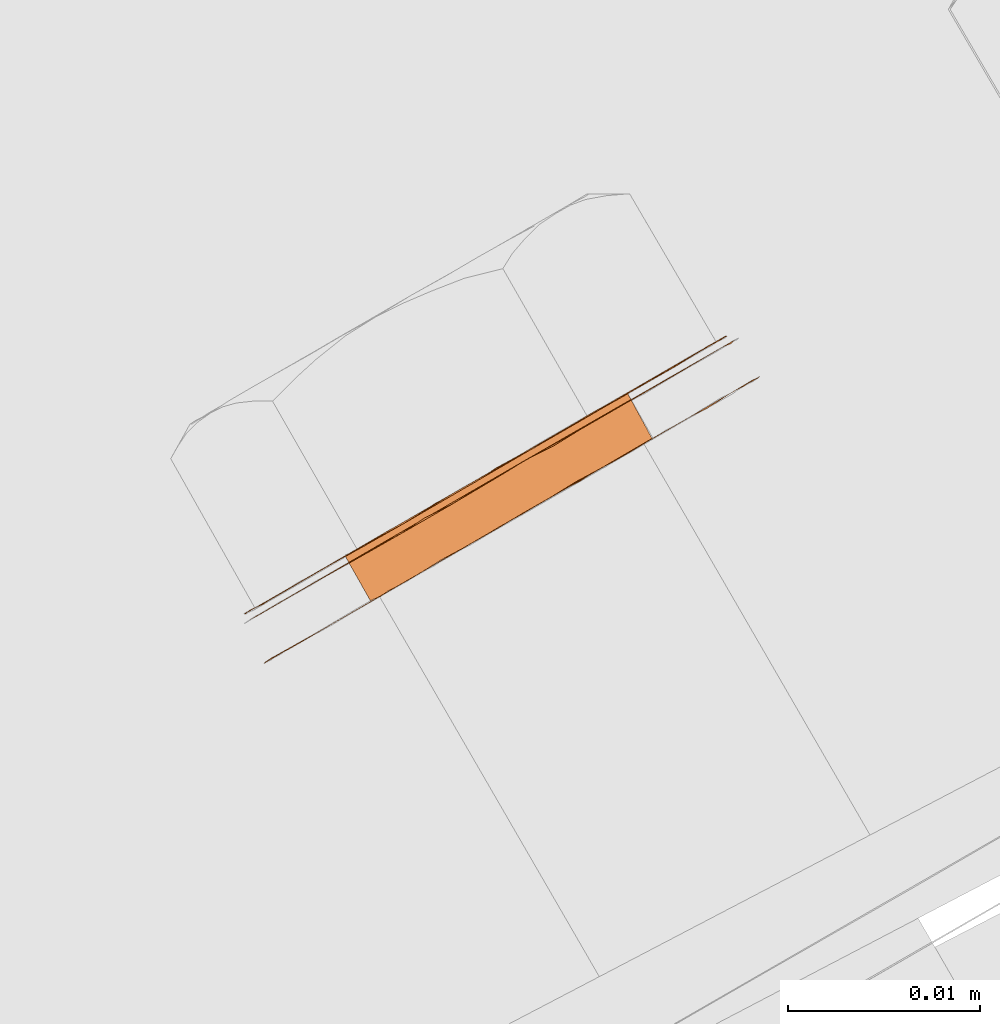
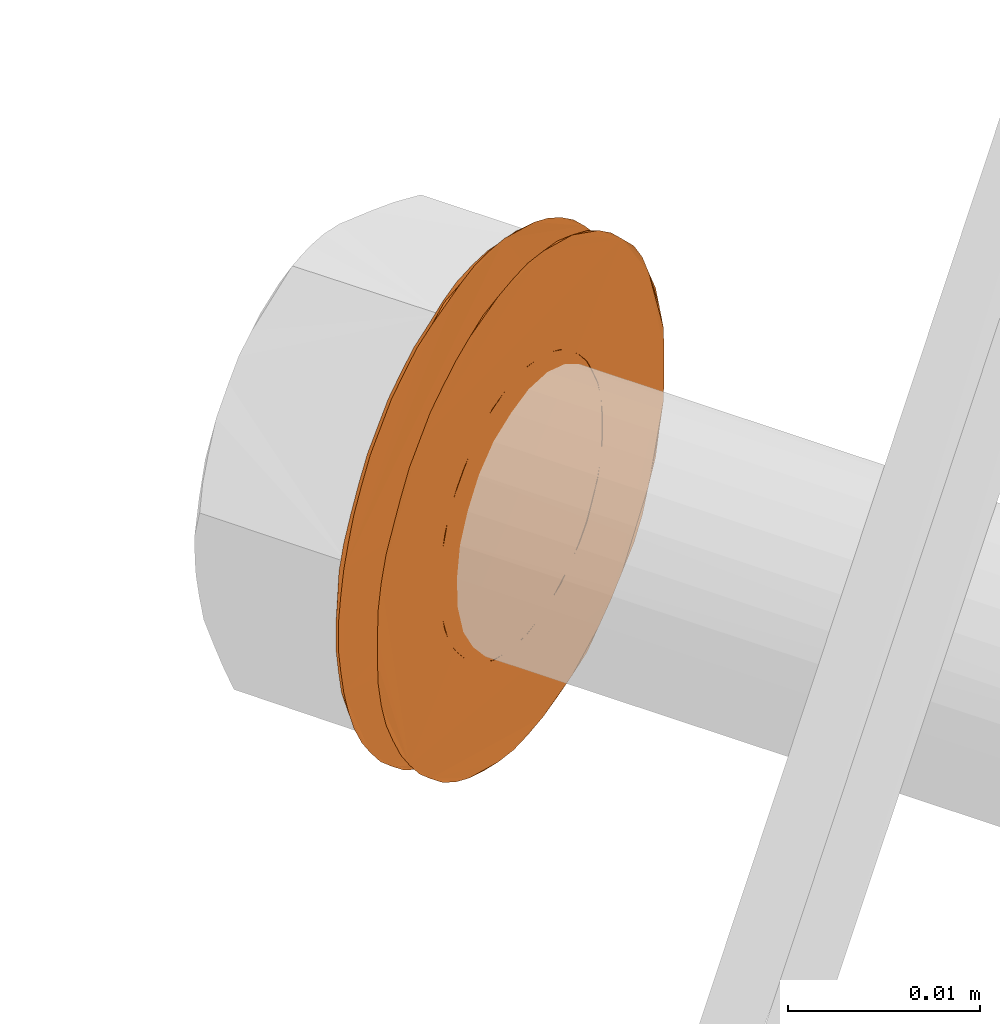
# One storey, part 126 of 126: 1 proxy.
"""IFC2X3 building model written with IfcOpenShell, lengths in millimetres."""

from ifc_helpers import new_model, si_unit, origin, origin_with_axes, place, context, project, spatial, faceted_brep, material, element, save


model = new_model("IFC2X3")

# Units and contexts
context_of_model_1 = context(None, 3, precision=0.1, world=origin())
context_of_model_2 = context(None, 3, precision=0.1, world=origin())
ifc_project = project(units=[si_unit("LENGTHUNIT", "METRE", prefix="MILLI"), si_unit("AREAUNIT", "SQUARE_METRE", prefix="CENTI"), si_unit("VOLUMEUNIT", "CUBIC_METRE", prefix="CENTI"), si_unit("MASSUNIT", "GRAM", prefix="KILO")], contexts=[context_of_model_1, context_of_model_2])

# Site, building, storey
site_placement = place(None, origin_with_axes())
site = spatial("IfcSite", under=ifc_project, at=site_placement, CompositionType="ELEMENT")
building_placement = place(site_placement, origin_with_axes())
building = spatial("IfcBuilding", under=site, at=building_placement, CompositionType="ELEMENT")
storey_placement = place(building_placement, origin_with_axes())
storey = spatial("IfcBuildingStorey", under=building, at=storey_placement, CompositionType="ELEMENT")

# Proxy
ifc_material = material(Name="STAHL")
proxy_placement = place(storey_placement, origin_with_axes())
element("IfcBuildingElementProxy", 1, at=proxy_placement, inside=storey, material=ifc_material, Name="profile", context=context_of_model_2, shape_type="Brep", body=[
    faceted_brep([(4267.3, 15131.6, 629.2), (4268.7, 15129.3, 629.2), (4268.0, 15128.9, 628.3), (4266.6, 15131.2, 628.3), (4277.7, 15137.7, 617.2), (4276.9, 15137.2, 616.4), (4278.3, 15134.9, 616.4), (4279.1, 15135.3, 617.2), (4276.0, 15136.7, 615.8), (4277.4, 15134.3, 615.8), (4275.1, 15136.1, 615.2), (4276.4, 15133.8, 615.2), (4274.1, 15135.6, 614.9), (4275.4, 15133.2, 614.9), (4273.0, 15135.0, 614.7), (4274.4, 15132.6, 614.7), (4272.0, 15134.3, 614.7), (4273.3, 15132.0, 614.7), (4270.9, 15133.7, 614.9), (4272.3, 15131.4, 614.9), (4269.9, 15133.2, 615.2), (4271.3, 15130.8, 615.2), (4269.0, 15132.6, 615.8), (4270.3, 15130.3, 615.8), (4268.1, 15132.1, 616.4), (4269.5, 15129.8, 616.4), (4267.3, 15131.6, 617.2), (4268.7, 15129.3, 617.2), (4266.6, 15131.2, 618.1), (4268.0, 15128.9, 618.1), (4266.1, 15130.9, 619.1), (4267.4, 15128.6, 619.1), (4265.6, 15130.7, 620.2), (4267.0, 15128.3, 620.2), (4265.3, 15130.5, 621.4), (4266.7, 15128.2, 621.4), (4265.2, 15130.4, 622.6), (4266.5, 15128.1, 622.6), (4265.2, 15130.4, 623.8), (4266.5, 15128.1, 623.8), (4265.3, 15130.5, 625.0), (4266.7, 15128.2, 625.0), (4265.6, 15130.7, 626.2), (4267.0, 15128.3, 626.2), (4266.1, 15130.9, 627.3), (4267.4, 15128.6, 627.3), (4260.9, 15124.8, 622.4), (4260.9, 15124.8, 624.0), (4261.0, 15124.9, 625.6), (4261.3, 15125.1, 627.1), (4261.7, 15125.3, 628.6), (4262.3, 15125.6, 630.0), (4263.0, 15126.0, 631.4), (4263.8, 15126.5, 632.7), (4264.7, 15127.0, 633.8), (4265.7, 15127.6, 634.9), (4266.8, 15128.2, 635.8), (4268.0, 15128.9, 636.6), (4269.2, 15129.6, 637.2), (4270.5, 15130.4, 637.7), (4271.8, 15131.1, 638.0), (4273.2, 15131.9, 638.2), (4274.5, 15132.7, 638.2), (4275.9, 15133.5, 638.0), (4277.2, 15134.3, 637.7), (4278.5, 15135.0, 637.2), (4279.8, 15135.7, 636.6), (4280.9, 15136.4, 635.8), (4282.0, 15137.0, 634.9), (4283.0, 15137.6, 633.8), (4284.0, 15138.1, 632.7), (4284.8, 15138.6, 631.4), (4285.4, 15139.0, 630.0), (4286.0, 15139.3, 628.6), (4286.4, 15139.6, 627.1), (4286.7, 15139.7, 625.6), (4286.8, 15139.8, 624.0), (4286.8, 15139.8, 622.4), (4286.7, 15139.7, 620.9), (4286.4, 15139.6, 619.3), (4286.0, 15139.3, 617.8), (4285.4, 15139.0, 616.4), (4284.8, 15138.6, 615.0), (4284.0, 15138.1, 613.8), (4283.0, 15137.6, 612.6), (4282.0, 15137.0, 611.6), (4280.9, 15136.4, 610.6), (4279.8, 15135.7, 609.8), (4278.5, 15135.0, 609.2), (4277.2, 15134.3, 608.7), (4275.9, 15133.5, 608.4), (4274.5, 15132.7, 608.2), (4273.2, 15131.9, 608.2), (4271.8, 15131.1, 608.4), (4270.5, 15130.4, 608.7), (4269.2, 15129.6, 609.2), (4268.0, 15128.9, 609.8), (4266.8, 15128.2, 610.6), (4265.7, 15127.6, 611.6), (4264.7, 15127.0, 612.6), (4263.8, 15126.5, 613.8), (4263.0, 15126.0, 615.0), (4262.3, 15125.6, 616.4), (4261.7, 15125.3, 617.8), (4261.3, 15125.1, 619.3), (4260.2, 15127.1, 619.3), (4260.6, 15127.3, 617.8), (4261.1, 15127.6, 616.4), (4261.8, 15128.0, 615.0), (4262.6, 15128.5, 613.8), (4263.5, 15129.0, 612.6), (4264.5, 15129.6, 611.6), (4265.6, 15130.2, 610.6), (4266.8, 15130.9, 609.8), (4268.1, 15131.6, 609.2), (4269.3, 15132.4, 608.7), (4270.7, 15133.1, 608.4), (4272.0, 15133.9, 608.2), (4273.4, 15134.7, 608.2), (4274.7, 15135.5, 608.4), (4276.1, 15136.2, 608.7), (4277.4, 15137.0, 609.2), (4278.6, 15137.7, 609.8), (4279.8, 15138.4, 610.6), (4280.9, 15139.0, 611.6), (4281.9, 15139.6, 612.6), (4282.8, 15140.1, 613.8), (4283.6, 15140.6, 615.0), (4284.3, 15141.0, 616.4), (4284.8, 15141.3, 617.8), (4285.3, 15141.5, 619.3), (4285.5, 15141.7, 620.9), (4285.7, 15141.8, 622.4), (4285.7, 15141.8, 624.0), (4285.5, 15141.7, 625.6), (4285.3, 15141.5, 627.1), (4284.8, 15141.3, 628.6), (4284.3, 15141.0, 630.0), (4283.6, 15140.6, 631.4), (4282.8, 15140.1, 632.7), (4281.9, 15139.6, 633.8), (4280.9, 15139.0, 634.9), (4279.8, 15138.4, 635.8), (4278.6, 15137.7, 636.6), (4277.4, 15137.0, 637.2), (4276.1, 15136.2, 637.7), (4274.7, 15135.5, 638.0), (4273.4, 15134.7, 638.2), (4272.0, 15133.9, 638.2), (4270.7, 15133.1, 638.0), (4269.3, 15132.4, 637.7), (4268.1, 15131.6, 637.2), (4266.8, 15130.9, 636.6), (4265.6, 15130.2, 635.8), (4264.5, 15129.6, 634.9), (4263.5, 15129.0, 633.8), (4262.6, 15128.5, 632.7), (4261.8, 15128.0, 631.4), (4261.1, 15127.6, 630.0), (4260.6, 15127.3, 628.6), (4260.2, 15127.1, 627.1), (4259.9, 15126.9, 625.6), (4259.7, 15126.8, 624.0), (4259.7, 15126.8, 622.4), (4259.9, 15126.9, 620.9), (4261.0, 15124.9, 620.9), (4273.5, 15135.2, 637.8), (4272.2, 15134.5, 637.8), (4270.8, 15133.7, 637.7), (4269.5, 15132.9, 637.4), (4268.2, 15132.1, 636.9), (4266.9, 15131.4, 636.3), (4265.7, 15130.7, 635.5), (4264.6, 15130.1, 634.6), (4263.6, 15129.5, 633.5), (4262.7, 15129.0, 632.4), (4261.9, 15128.5, 631.1), (4261.2, 15128.1, 629.7), (4260.6, 15127.8, 628.2), (4260.2, 15127.6, 626.7), (4260.0, 15127.4, 625.2), (4259.9, 15127.4, 623.6), (4259.9, 15127.4, 622.0), (4260.1, 15127.5, 620.5), (4260.4, 15127.7, 618.9), (4260.9, 15127.9, 617.4), (4261.5, 15128.3, 616.0), (4262.2, 15128.7, 614.7), (4263.1, 15129.2, 613.5), (4264.1, 15129.8, 612.3), (4265.1, 15130.4, 611.4), (4266.3, 15131.1, 610.5), (4267.5, 15131.8, 609.8), (4268.8, 15132.5, 609.3), (4270.1, 15133.3, 608.9), (4271.5, 15134.1, 608.7), (4272.9, 15134.8, 608.6), (4274.2, 15135.6, 608.7), (4275.6, 15136.4, 609.0), (4276.9, 15137.2, 609.5), (4278.1, 15137.9, 610.1), (4279.3, 15138.6, 610.9), (4280.4, 15139.2, 611.8), (4281.5, 15139.8, 612.9), (4282.4, 15140.3, 614.1), (4283.2, 15140.8, 615.3), (4283.8, 15141.2, 616.7), (4284.4, 15141.5, 618.2), (4284.8, 15141.7, 619.7), (4285.0, 15141.9, 621.2), (4285.2, 15141.9, 622.8), (4285.1, 15141.9, 624.4), (4284.9, 15141.8, 626.0), (4284.6, 15141.6, 627.5), (4284.1, 15141.4, 629.0), (4283.5, 15141.0, 630.4), (4282.8, 15140.6, 631.7), (4281.9, 15140.1, 633.0), (4281.0, 15139.5, 634.1), (4279.9, 15138.9, 635.1), (4278.7, 15138.2, 635.9), (4277.5, 15137.5, 636.6), (4276.2, 15136.8, 637.2), (4274.9, 15136.0, 637.5), (4272.0, 15134.3, 631.7), (4270.9, 15133.7, 631.5), (4269.9, 15133.2, 631.2), (4269.0, 15132.6, 630.7), (4268.1, 15132.1, 630.0), (4278.4, 15138.1, 618.1), (4279.0, 15138.4, 619.1), (4279.4, 15138.6, 620.2), (4279.7, 15138.8, 621.4), (4279.9, 15138.9, 622.6), (4279.9, 15138.9, 623.8), (4279.7, 15138.8, 625.0), (4279.4, 15138.6, 626.2), (4279.0, 15138.4, 627.3), (4278.4, 15138.1, 628.3), (4277.7, 15137.7, 629.2), (4276.9, 15137.2, 630.0), (4276.0, 15136.7, 630.7), (4275.1, 15136.1, 631.2), (4274.1, 15135.6, 631.5), (4273.0, 15135.0, 631.7), (4280.8, 15136.3, 620.2), (4281.1, 15136.5, 621.4), (4280.3, 15136.0, 619.1), (4279.8, 15135.7, 618.1), (4269.5, 15129.8, 630.0), (4270.3, 15130.3, 630.7), (4271.3, 15130.8, 631.2), (4272.3, 15131.4, 631.5), (4273.3, 15132.0, 631.7), (4274.4, 15132.6, 631.7), (4275.4, 15133.2, 631.5), (4276.4, 15133.8, 631.2), (4277.4, 15134.3, 630.7), (4278.3, 15134.9, 630.0), (4279.1, 15135.3, 629.2), (4279.8, 15135.7, 628.3), (4280.3, 15136.0, 627.3), (4280.8, 15136.3, 626.2), (4281.1, 15136.5, 625.0), (4281.2, 15136.5, 623.8), (4281.2, 15136.5, 622.6)], [[[0, 1, 2, 3]], [[4, 5, 6, 7]], [[5, 8, 9, 6]], [[8, 10, 11, 9]], [[10, 12, 13, 11]], [[12, 14, 15, 13]], [[14, 16, 17, 15]], [[16, 18, 19, 17]], [[18, 20, 21, 19]], [[20, 22, 23, 21]], [[22, 24, 25, 23]], [[24, 26, 27, 25]], [[26, 28, 29, 27]], [[28, 30, 31, 29]], [[30, 32, 33, 31]], [[32, 34, 35, 33]], [[34, 36, 37, 35]], [[36, 38, 39, 37]], [[38, 40, 41, 39]], [[40, 42, 43, 41]], [[42, 44, 45, 43]], [[44, 3, 2, 45]], [[46, 47, 48, 49, 50, 51, 52, 53, 54, 55, 56, 57, 58, 59, 60, 61, 62, 63, 64, 65, 66, 67, 68, 69, 70, 71, 72, 73, 74, 75, 76, 77, 78, 79, 80, 81, 82, 83, 84, 85, 86, 87, 88, 89, 90, 91, 92, 93, 94, 95, 96, 97, 98, 99, 100, 101, 102, 103, 104, 105, 106, 107, 108, 109, 110, 111, 112, 113, 114, 115, 116, 117, 118, 119, 120, 121, 122, 123, 124, 125, 126, 127, 128, 129, 130, 131, 132, 133, 134, 135, 136, 137, 138, 139, 140, 141, 142, 143, 144, 145, 146, 147, 148, 149, 150, 151, 152, 153, 154, 155, 156, 157, 158, 159, 160, 161, 162, 163, 164, 105, 104, 165]], [[163, 162, 161, 160, 159, 158, 157, 156, 155, 154, 153, 152, 151, 150, 149, 148, 147, 166, 167, 168, 169, 170, 171, 172, 173, 174, 175, 176, 177, 178, 179, 180, 181, 182, 183, 184, 185, 186, 187, 188, 189, 190, 191, 192, 193, 194, 195, 196, 197, 198, 199, 200, 201, 202, 203, 204, 205, 206, 207, 208, 209, 210, 211, 212, 213, 214, 215, 216, 217, 218, 219, 220, 221, 222, 223, 166, 147, 146, 145, 144, 143, 142, 141, 140, 139, 138, 137, 136, 135, 134, 133, 132, 131, 130, 129, 128, 127, 126, 125, 124, 123, 122, 121, 120, 119, 118, 117, 116, 115, 114, 113, 112, 111, 110, 109, 108, 107, 106, 105, 164]], [[181, 180, 179, 178, 177, 176, 175, 174, 173, 172, 171, 170, 169, 168, 167, 224, 225, 226, 227, 228, 0, 3, 44, 42, 40, 38, 36, 34, 32, 30, 28, 26, 24, 22, 20, 18, 16, 14, 12, 10, 8, 5, 4, 229, 230, 231, 232, 233, 234, 235, 236, 237, 238, 239, 240, 241, 242, 243, 244, 224, 167, 166, 223, 222, 221, 220, 219, 218, 217, 216, 215, 214, 213, 212, 211, 210, 209, 208, 207, 206, 205, 204, 203, 202, 201, 200, 199, 198, 197, 196, 195, 194, 193, 192, 191, 190, 189, 188, 187, 186, 185, 184, 183, 182]], [[231, 245, 246, 232]], [[230, 247, 245, 231]], [[229, 248, 247, 230]], [[228, 249, 1, 0]], [[4, 7, 248, 229]], [[227, 250, 249, 228]], [[226, 251, 250, 227]], [[225, 252, 251, 226]], [[224, 253, 252, 225]], [[244, 254, 253, 224]], [[243, 255, 254, 244]], [[242, 256, 255, 243]], [[241, 257, 256, 242]], [[240, 258, 257, 241]], [[239, 259, 258, 240]], [[238, 260, 259, 239]], [[237, 261, 260, 238]], [[236, 262, 261, 237]], [[235, 263, 262, 236]], [[234, 264, 263, 235]], [[233, 265, 264, 234]], [[232, 246, 265, 233]], [[47, 46, 165, 104, 103, 102, 101, 100, 99, 98, 97, 96, 95, 94, 93, 92, 91, 90, 89, 88, 87, 86, 85, 84, 83, 82, 81, 80, 79, 78, 77, 76, 75, 74, 73, 72, 71, 70, 69, 68, 67, 66, 65, 64, 63, 62, 61, 60, 253, 254, 255, 256, 257, 258, 259, 260, 261, 262, 263, 264, 265, 246, 245, 247, 248, 7, 6, 9, 11, 13, 15, 17, 19, 21, 23, 25, 27, 29, 31, 33, 35, 37, 39, 41, 43, 45, 2, 1, 249, 250, 251, 252, 253, 60, 59, 58, 57, 56, 55, 54, 53, 52, 51, 50, 49, 48]]]),
])

save(model, "model.ifc")
